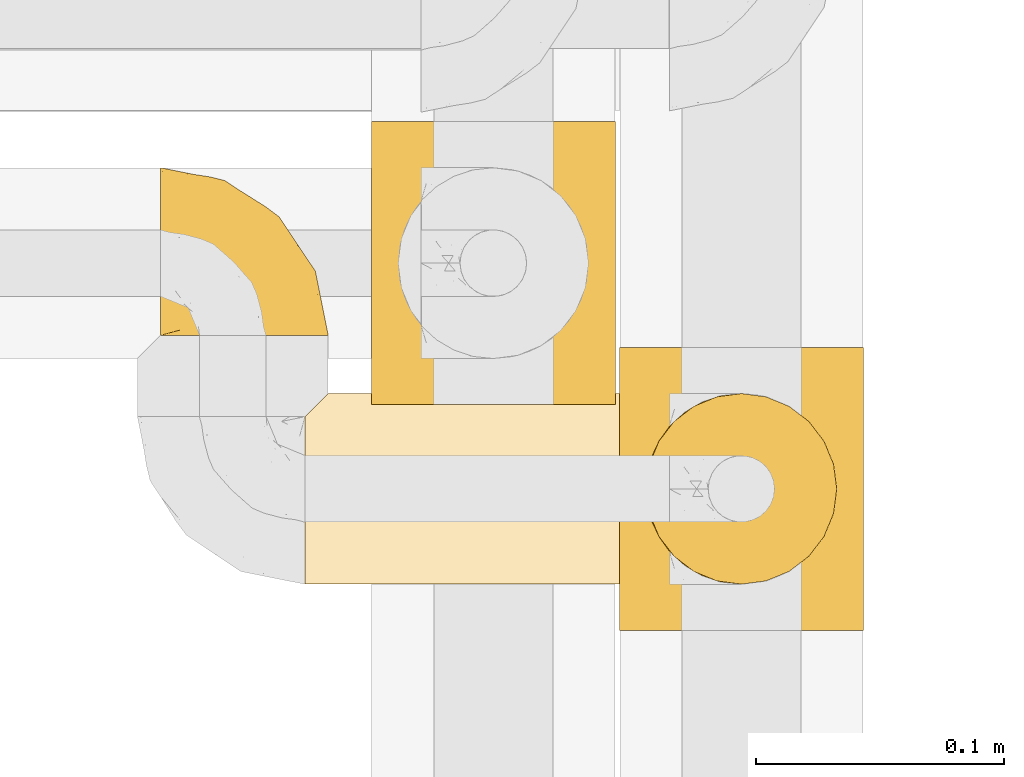
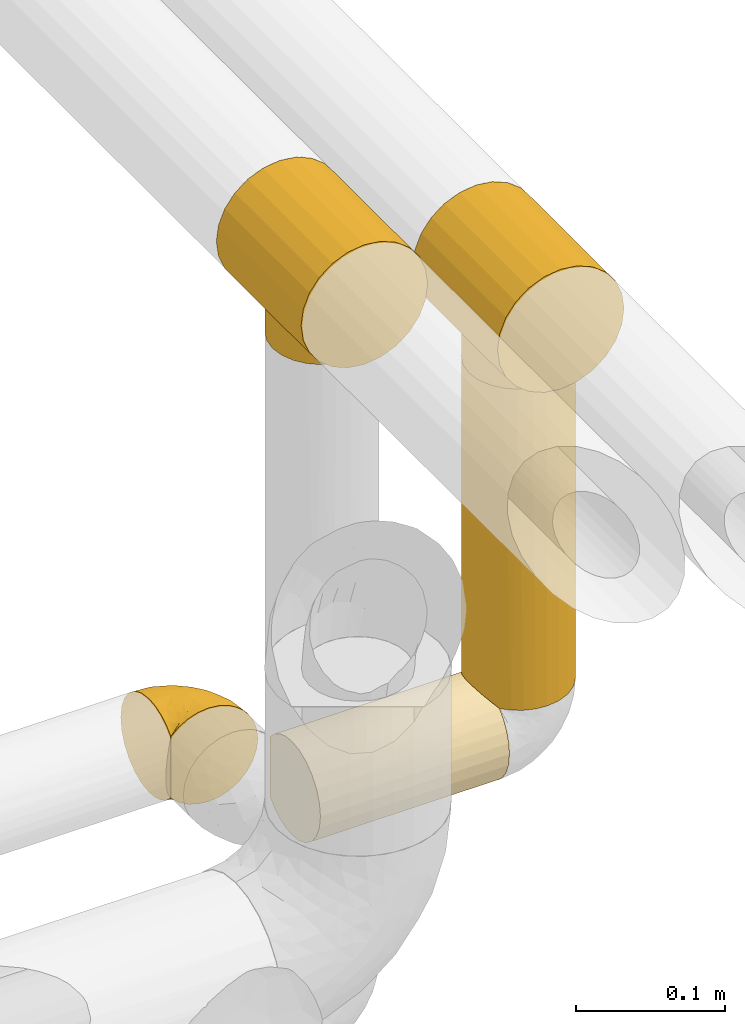
# One storey, part 496 of 827: 5 coverings.
"""IFC2X3 building model written with IfcOpenShell, lengths in millimetres."""

from ifc_helpers import new_model, entity, si_unit, converted_unit, derived_unit, direction, frame, origin, place, context, subcontext, project, spatial, faceted_brep, element, save


model = new_model("IFC2X3")

# Units and contexts
model_context = context("Model", 3, precision=0.01, world=origin(), true_north=direction((6.12303176911189e-17, 1.0)))
body_context = subcontext(model_context, "Body", "Model", "MODEL_VIEW")
ifc_project = project(units=[si_unit("LENGTHUNIT", "METRE", prefix="MILLI"), si_unit("AREAUNIT", "SQUARE_METRE"), si_unit("VOLUMEUNIT", "CUBIC_METRE"), converted_unit("PLANEANGLEUNIT", "DEGREE", entity("IfcRatioMeasure", 0.0174532925199433), si_unit("PLANEANGLEUNIT", "RADIAN"), dimensions=[0, 0, 0, 0, 0, 0, 0]), si_unit("MASSUNIT", "GRAM", prefix="KILO"), derived_unit("MASSDENSITYUNIT", [(si_unit("MASSUNIT", "GRAM", prefix="KILO"), 1), (si_unit("LENGTHUNIT", "METRE"), -3)]), derived_unit("MOMENTOFINERTIAUNIT", [(si_unit("LENGTHUNIT", "METRE"), 4)]), si_unit("TIMEUNIT", "SECOND"), si_unit("FREQUENCYUNIT", "HERTZ"), si_unit("THERMODYNAMICTEMPERATUREUNIT", "DEGREE_CELSIUS"), derived_unit("THERMALTRANSMITTANCEUNIT", [(si_unit("MASSUNIT", "GRAM", prefix="KILO"), 1), (si_unit("THERMODYNAMICTEMPERATUREUNIT", "KELVIN"), -1), (si_unit("TIMEUNIT", "SECOND"), -3)]), derived_unit("VOLUMETRICFLOWRATEUNIT", [(si_unit("LENGTHUNIT", "METRE"), 3), (si_unit("TIMEUNIT", "SECOND"), -1)]), derived_unit("MASSFLOWRATEUNIT", [(si_unit("MASSUNIT", "GRAM", prefix="KILO"), 1), (si_unit("TIMEUNIT", "SECOND"), -1)]), derived_unit("ROTATIONALFREQUENCYUNIT", [(si_unit("TIMEUNIT", "SECOND"), -1)]), si_unit("ELECTRICCURRENTUNIT", "AMPERE"), si_unit("ELECTRICVOLTAGEUNIT", "VOLT"), si_unit("POWERUNIT", "WATT"), si_unit("FORCEUNIT", "NEWTON", prefix="KILO"), si_unit("ILLUMINANCEUNIT", "LUX"), si_unit("LUMINOUSFLUXUNIT", "LUMEN"), si_unit("LUMINOUSINTENSITYUNIT", "CANDELA"), derived_unit("USERDEFINED", [(si_unit("MASSUNIT", "GRAM", prefix="KILO"), -1), (si_unit("LENGTHUNIT", "METRE"), -2), (si_unit("TIMEUNIT", "SECOND"), 3), (si_unit("LUMINOUSFLUXUNIT", "LUMEN"), 1)]), derived_unit("LINEARVELOCITYUNIT", [(si_unit("LENGTHUNIT", "METRE"), 1), (si_unit("TIMEUNIT", "SECOND"), -1)]), si_unit("PRESSUREUNIT", "PASCAL"), derived_unit("USERDEFINED", [(si_unit("LENGTHUNIT", "METRE"), -2), (si_unit("MASSUNIT", "GRAM", prefix="KILO"), 1), (si_unit("TIMEUNIT", "SECOND"), -2)]), derived_unit("LINEARFORCEUNIT", [(si_unit("MASSUNIT", "GRAM", prefix="KILO"), 1), (si_unit("LENGTHUNIT", "METRE"), 1), (si_unit("TIMEUNIT", "SECOND"), -2), (si_unit("LENGTHUNIT", "METRE"), -1)]), derived_unit("PLANARFORCEUNIT", [(si_unit("MASSUNIT", "GRAM", prefix="KILO"), 1), (si_unit("LENGTHUNIT", "METRE"), 1), (si_unit("TIMEUNIT", "SECOND"), -2), (si_unit("LENGTHUNIT", "METRE"), -2)])], contexts=[model_context])

# Site, building, storey
site_placement = place(None, origin())
site = spatial("IfcSite", under=ifc_project, at=site_placement, CompositionType="ELEMENT")
building_placement = place(site_placement, origin())
building = spatial("IfcBuilding", under=site, at=building_placement, CompositionType="ELEMENT")
storey_placement = place(building_placement, frame((0.0, 0.0, 28200.0)))
storey = spatial("IfcBuildingStorey", under=building, at=storey_placement, Name="08", CompositionType="ELEMENT", Elevation=28200.0)

# Coverings
covering_1_placement = place(storey_placement, frame((61001.89, 16322.84, 2942.74)))
element("IfcCovering", 1, at=covering_1_placement, inside=storey, Name=":ADSK_", ObjectType=":ADSK_", PredefinedType="INSULATION", context=body_context, shape_type="Brep", body=[
    faceted_brep([(26.17, 114.0, 99.57), (38.02, 114.0, 104.48), (50.75, 114.0, 106.15), (63.47, 114.0, 104.48), (75.32, 114.0, 99.57), (85.5, 114.0, 91.75), (93.31, 114.0, 81.58), (98.22, 114.0, 69.72), (99.9, 114.0, 57.0), (98.22, 114.0, 44.28), (93.31, 114.0, 32.43), (85.5, 114.0, 22.25), (80.41, 114.0, 18.34), (75.32, 114.0, 14.43), (69.39, 114.0, 11.98), (63.47, 114.0, 9.52), (60.29, 114.0, 9.11), (57.11, 114.0, 8.69), (53.93, 114.0, 8.27), (50.75, 114.0, 7.85), (47.57, 114.0, 8.27), (44.38, 114.0, 8.69), (41.2, 114.0, 9.11), (38.02, 114.0, 9.52), (32.1, 114.0, 11.98), (26.17, 114.0, 14.43), (21.08, 114.0, 18.34), (15.99, 114.0, 22.25), (8.18, 114.0, 32.43), (3.27, 114.0, 44.28), (1.6, 114.0, 57.0), (3.27, 114.0, 69.72), (8.18, 114.0, 81.58), (15.99, 114.0, 91.75), (98.22, 0.0, 69.72), (93.31, 0.0, 81.58), (85.5, 0.0, 91.75), (75.32, 0.0, 99.57), (63.47, 0.0, 104.48), (50.75, 0.0, 106.15), (38.02, 0.0, 104.48), (26.17, 0.0, 99.57), (15.99, 0.0, 91.75), (8.18, 0.0, 81.58), (3.27, 0.0, 69.72), (1.6, 0.0, 57.0), (3.27, 0.0, 44.28), (8.18, 0.0, 32.43), (15.99, 0.0, 22.25), (21.08, 0.0, 18.34), (26.17, 0.0, 14.43), (32.1, 0.0, 11.98), (38.02, 0.0, 9.52), (41.2, 0.0, 9.11), (44.38, 0.0, 8.69), (47.57, 0.0, 8.27), (50.75, 0.0, 7.85), (53.93, 0.0, 8.27), (57.11, 0.0, 8.69), (60.29, 0.0, 9.11), (63.47, 0.0, 9.52), (69.39, 0.0, 11.98), (75.32, 0.0, 14.43), (80.41, 0.0, 18.34), (85.5, 0.0, 22.25), (93.31, 0.0, 32.43), (98.22, 0.0, 44.28), (99.9, 0.0, 57.0), (80.86, 33.09, 18.16), (85.26, 40.05, 22.01), (75.08, 27.23, 14.3), (67.99, 91.37, 10.97), (88.15, 48.08, 25.11), (89.2, 57.0, 26.38), (88.15, 65.92, 25.11), (50.75, 95.45, 7.85), (50.75, 18.55, 7.85), (80.86, 80.91, 18.16), (85.26, 73.95, 22.01), (75.08, 86.77, 14.3), (67.99, 22.63, 10.97), (63.86, 92.88, 9.83), (59.73, 19.61, 8.68), (55.24, 19.08, 8.26), (63.86, 21.12, 9.83), (59.73, 94.39, 8.68), (55.24, 94.92, 8.26), (46.25, 19.08, 8.26), (37.63, 21.12, 9.83), (26.41, 27.23, 14.3), (41.76, 19.61, 8.68), (33.5, 22.63, 10.97), (37.63, 92.88, 9.83), (41.76, 94.39, 8.68), (46.25, 94.92, 8.26), (26.41, 86.77, 14.3), (33.5, 91.37, 10.97), (20.63, 80.91, 18.16), (20.63, 33.09, 18.16), (16.23, 40.05, 22.01), (13.34, 48.08, 25.11), (12.3, 57.0, 26.38), (16.23, 73.95, 22.01), (13.34, 65.92, 25.11), (89.2, 57.0, 0.0), (87.89, 47.05, 0.0), (84.04, 37.77, 0.0), (77.93, 29.81, 0.0), (69.97, 23.7, 0.0), (60.7, 19.86, 0.0), (50.75, 18.55, 0.0), (40.79, 19.86, 0.0), (31.52, 23.7, 0.0), (23.56, 29.81, 0.0), (17.45, 37.77, 0.0), (13.61, 47.05, 0.0), (12.3, 57.0, 0.0), (13.61, 66.95, 0.0), (17.45, 76.22, 0.0), (23.56, 84.19, 0.0), (31.52, 90.3, 0.0), (40.79, 94.14, 0.0), (50.75, 95.45, 0.0), (60.7, 94.14, 0.0), (69.97, 90.3, 0.0), (77.93, 84.19, 0.0), (84.04, 76.22, 0.0), (87.89, 66.95, 0.0)], [[[0, 1, 2, 3, 4, 5, 6, 7, 8, 9, 10, 11, 12, 13, 14, 15, 16, 17, 18, 19, 20, 21, 22, 23, 24, 25, 26, 27, 28, 29, 30, 31, 32, 33]], [[34, 35, 36, 37, 38, 39, 40, 41, 42, 43, 44, 45, 46, 47, 48, 49, 50, 51, 52, 53, 54, 55, 56, 57, 58, 59, 60, 61, 62, 63, 64, 65, 66, 67]], [[37, 36, 5, 4]], [[2, 39, 38, 3]], [[38, 37, 4, 3]], [[6, 35, 34, 7]], [[7, 34, 67, 8]], [[5, 36, 35, 6]], [[66, 9, 8, 67]], [[65, 10, 9, 66]], [[64, 68, 69]], [[63, 62, 70]], [[71, 15, 14]], [[69, 72, 64]], [[68, 64, 63]], [[64, 72, 65]], [[72, 73, 65]], [[74, 11, 10]], [[18, 75, 19]], [[76, 57, 56]], [[77, 11, 78]], [[78, 11, 74]], [[79, 12, 77]], [[74, 10, 73]], [[73, 10, 65]], [[70, 61, 80]], [[61, 70, 62]], [[80, 61, 60]], [[15, 71, 81]], [[82, 59, 58]], [[83, 57, 76]], [[84, 59, 82]], [[82, 58, 83]], [[83, 58, 57]], [[60, 84, 80]], [[17, 85, 86]], [[79, 13, 12]], [[59, 84, 60]], [[79, 14, 13]], [[14, 79, 71]], [[85, 17, 16]], [[77, 12, 11]], [[18, 17, 86]], [[15, 81, 16]], [[16, 81, 85]], [[75, 18, 86]], [[68, 63, 70]], [[54, 87, 55]], [[53, 52, 88]], [[76, 55, 87]], [[50, 89, 51]], [[54, 90, 87]], [[91, 51, 89]], [[91, 52, 51]], [[88, 90, 53]], [[92, 22, 93]], [[93, 21, 94]], [[75, 20, 19]], [[55, 76, 56]], [[20, 75, 94]], [[95, 25, 24]], [[90, 54, 53]], [[24, 23, 96]], [[95, 97, 26]], [[96, 23, 92]], [[89, 49, 98]], [[89, 50, 49]], [[94, 21, 20]], [[98, 48, 99]], [[48, 98, 49]], [[99, 48, 100]], [[52, 91, 88]], [[28, 47, 46, 29]], [[101, 100, 47]], [[47, 100, 48]], [[46, 45, 30, 29]], [[93, 22, 21]], [[102, 103, 27]], [[95, 24, 96]], [[26, 25, 95]], [[27, 97, 102]], [[103, 28, 27]], [[22, 92, 23]], [[101, 28, 103]], [[101, 47, 28]], [[97, 27, 26]], [[31, 44, 43, 32]], [[32, 43, 42, 33]], [[45, 44, 31, 30]], [[0, 41, 40, 1]], [[1, 40, 39, 2]], [[33, 42, 41, 0]], [[104, 105, 106, 107, 108, 109, 110, 111, 112, 113, 114, 115, 116, 117, 118, 119, 120, 121, 122, 123, 124, 125, 126, 127]], [[82, 110, 109]], [[80, 109, 108]], [[110, 82, 83, 76]], [[70, 80, 108]], [[109, 80, 84, 82]], [[108, 107, 70]], [[107, 106, 68]], [[106, 105, 69]], [[72, 105, 104]], [[68, 106, 69]], [[72, 69, 105]], [[73, 72, 104]], [[107, 68, 70]], [[74, 104, 127]], [[78, 127, 126]], [[73, 104, 74]], [[74, 127, 78]], [[126, 77, 78]], [[126, 125, 77]], [[79, 125, 124]], [[124, 123, 71]], [[122, 85, 123]], [[71, 79, 124]], [[122, 75, 86, 85]], [[123, 85, 81, 71]], [[125, 79, 77]], [[93, 122, 121]], [[96, 121, 120]], [[122, 93, 94, 75]], [[95, 96, 120]], [[121, 96, 92, 93]], [[120, 119, 95]], [[97, 119, 118]], [[118, 117, 102]], [[116, 103, 117]], [[97, 118, 102]], [[103, 102, 117]], [[101, 103, 116]], [[119, 97, 95]], [[100, 116, 115]], [[99, 115, 114]], [[101, 116, 100]], [[100, 115, 99]], [[114, 98, 99]], [[114, 113, 98]], [[89, 113, 112]], [[112, 111, 91]], [[110, 90, 111]], [[91, 89, 112]], [[110, 76, 87, 90]], [[111, 90, 88, 91]], [[113, 89, 98]]]),
])
covering_2_placement = place(storey_placement, frame((61101.89, 16231.88, 2942.74)))
element("IfcCovering", 2, at=covering_2_placement, inside=storey, Name=":ADSK_", ObjectType=":ADSK_", PredefinedType="INSULATION", context=body_context, shape_type="Brep", body=[
    faceted_brep([(26.17, 114.0, 99.57), (38.02, 114.0, 104.48), (50.75, 114.0, 106.15), (63.47, 114.0, 104.48), (75.32, 114.0, 99.57), (85.5, 114.0, 91.75), (93.31, 114.0, 81.58), (98.22, 114.0, 69.72), (99.9, 114.0, 57.0), (98.22, 114.0, 44.28), (93.31, 114.0, 32.43), (85.5, 114.0, 22.25), (80.41, 114.0, 18.34), (75.32, 114.0, 14.43), (69.39, 114.0, 11.98), (63.47, 114.0, 9.52), (60.29, 114.0, 9.11), (57.11, 114.0, 8.69), (53.93, 114.0, 8.27), (50.75, 114.0, 7.85), (47.57, 114.0, 8.27), (44.38, 114.0, 8.69), (41.2, 114.0, 9.11), (38.02, 114.0, 9.52), (32.1, 114.0, 11.98), (26.17, 114.0, 14.43), (21.08, 114.0, 18.34), (15.99, 114.0, 22.25), (8.18, 114.0, 32.43), (3.27, 114.0, 44.28), (1.6, 114.0, 57.0), (3.27, 114.0, 69.72), (8.18, 114.0, 81.58), (15.99, 114.0, 91.75), (98.22, 0.0, 69.72), (93.31, 0.0, 81.58), (85.5, 0.0, 91.75), (75.32, 0.0, 99.57), (63.47, 0.0, 104.48), (50.75, 0.0, 106.15), (38.02, 0.0, 104.48), (26.17, 0.0, 99.57), (15.99, 0.0, 91.75), (8.18, 0.0, 81.58), (3.27, 0.0, 69.72), (1.6, 0.0, 57.0), (3.27, 0.0, 44.28), (8.18, 0.0, 32.43), (15.99, 0.0, 22.25), (21.08, 0.0, 18.34), (26.17, 0.0, 14.43), (32.1, 0.0, 11.98), (38.02, 0.0, 9.52), (41.2, 0.0, 9.11), (44.38, 0.0, 8.69), (47.57, 0.0, 8.27), (50.75, 0.0, 7.85), (53.93, 0.0, 8.27), (57.11, 0.0, 8.69), (60.29, 0.0, 9.11), (63.47, 0.0, 9.52), (69.39, 0.0, 11.98), (75.32, 0.0, 14.43), (80.41, 0.0, 18.34), (85.5, 0.0, 22.25), (93.31, 0.0, 32.43), (98.22, 0.0, 44.28), (99.9, 0.0, 57.0), (80.86, 33.09, 18.16), (85.26, 40.05, 22.01), (75.08, 27.23, 14.3), (67.99, 91.37, 10.97), (88.15, 48.08, 25.11), (89.2, 57.0, 26.38), (88.15, 65.92, 25.11), (50.75, 95.45, 7.85), (50.75, 18.55, 7.85), (80.86, 80.91, 18.16), (85.26, 73.95, 22.01), (75.08, 86.77, 14.3), (67.99, 22.63, 10.97), (63.86, 92.88, 9.83), (59.73, 19.61, 8.68), (55.24, 19.08, 8.26), (63.86, 21.12, 9.83), (59.73, 94.39, 8.68), (55.24, 94.92, 8.26), (46.25, 19.08, 8.26), (37.63, 21.12, 9.83), (26.41, 27.23, 14.3), (41.76, 19.61, 8.68), (33.5, 22.63, 10.97), (37.63, 92.88, 9.83), (41.76, 94.39, 8.68), (46.25, 94.92, 8.26), (26.41, 86.77, 14.3), (33.5, 91.37, 10.97), (20.63, 80.91, 18.16), (20.63, 33.09, 18.16), (16.23, 40.05, 22.01), (13.34, 48.08, 25.11), (12.3, 57.0, 26.38), (16.23, 73.95, 22.01), (13.34, 65.92, 25.11), (89.2, 57.0, 0.0), (87.89, 47.05, 0.0), (84.04, 37.77, 0.0), (77.93, 29.81, 0.0), (69.97, 23.7, 0.0), (60.7, 19.86, 0.0), (50.75, 18.55, 0.0), (40.79, 19.86, 0.0), (31.52, 23.7, 0.0), (23.56, 29.81, 0.0), (17.45, 37.77, 0.0), (13.61, 47.05, 0.0), (12.3, 57.0, 0.0), (13.61, 66.95, 0.0), (17.45, 76.22, 0.0), (23.56, 84.19, 0.0), (31.52, 90.3, 0.0), (40.79, 94.14, 0.0), (50.75, 95.45, 0.0), (60.7, 94.14, 0.0), (69.97, 90.3, 0.0), (77.93, 84.19, 0.0), (84.04, 76.22, 0.0), (87.89, 66.95, 0.0)], [[[0, 1, 2, 3, 4, 5, 6, 7, 8, 9, 10, 11, 12, 13, 14, 15, 16, 17, 18, 19, 20, 21, 22, 23, 24, 25, 26, 27, 28, 29, 30, 31, 32, 33]], [[34, 35, 36, 37, 38, 39, 40, 41, 42, 43, 44, 45, 46, 47, 48, 49, 50, 51, 52, 53, 54, 55, 56, 57, 58, 59, 60, 61, 62, 63, 64, 65, 66, 67]], [[37, 36, 5, 4]], [[2, 39, 38, 3]], [[38, 37, 4, 3]], [[6, 35, 34, 7]], [[7, 34, 67, 8]], [[5, 36, 35, 6]], [[66, 9, 8, 67]], [[65, 10, 9, 66]], [[64, 68, 69]], [[63, 62, 70]], [[71, 15, 14]], [[69, 72, 64]], [[68, 64, 63]], [[64, 72, 65]], [[72, 73, 65]], [[74, 11, 10]], [[18, 75, 19]], [[76, 57, 56]], [[77, 11, 78]], [[78, 11, 74]], [[79, 12, 77]], [[74, 10, 73]], [[73, 10, 65]], [[70, 61, 80]], [[61, 70, 62]], [[80, 61, 60]], [[15, 71, 81]], [[82, 59, 58]], [[83, 57, 76]], [[84, 59, 82]], [[82, 58, 83]], [[83, 58, 57]], [[60, 84, 80]], [[17, 85, 86]], [[79, 13, 12]], [[59, 84, 60]], [[79, 14, 13]], [[14, 79, 71]], [[85, 17, 16]], [[77, 12, 11]], [[18, 17, 86]], [[15, 81, 16]], [[16, 81, 85]], [[75, 18, 86]], [[68, 63, 70]], [[54, 87, 55]], [[53, 52, 88]], [[76, 55, 87]], [[50, 89, 51]], [[54, 90, 87]], [[91, 51, 89]], [[91, 52, 51]], [[88, 90, 53]], [[92, 22, 93]], [[93, 21, 94]], [[75, 20, 19]], [[55, 76, 56]], [[20, 75, 94]], [[95, 25, 24]], [[90, 54, 53]], [[24, 23, 96]], [[95, 97, 26]], [[96, 23, 92]], [[89, 49, 98]], [[89, 50, 49]], [[94, 21, 20]], [[98, 48, 99]], [[48, 98, 49]], [[99, 48, 100]], [[52, 91, 88]], [[28, 47, 46, 29]], [[101, 100, 47]], [[47, 100, 48]], [[46, 45, 30, 29]], [[93, 22, 21]], [[102, 103, 27]], [[95, 24, 96]], [[26, 25, 95]], [[27, 97, 102]], [[103, 28, 27]], [[22, 92, 23]], [[101, 28, 103]], [[101, 47, 28]], [[97, 27, 26]], [[31, 44, 43, 32]], [[32, 43, 42, 33]], [[45, 44, 31, 30]], [[0, 41, 40, 1]], [[1, 40, 39, 2]], [[33, 42, 41, 0]], [[104, 105, 106, 107, 108, 109, 110, 111, 112, 113, 114, 115, 116, 117, 118, 119, 120, 121, 122, 123, 124, 125, 126, 127]], [[82, 110, 109]], [[80, 109, 108]], [[110, 82, 83, 76]], [[70, 80, 108]], [[109, 80, 84, 82]], [[108, 107, 70]], [[107, 106, 68]], [[106, 105, 69]], [[72, 105, 104]], [[68, 106, 69]], [[72, 69, 105]], [[73, 72, 104]], [[107, 68, 70]], [[74, 104, 127]], [[78, 127, 126]], [[73, 104, 74]], [[74, 127, 78]], [[126, 77, 78]], [[126, 125, 77]], [[79, 125, 124]], [[124, 123, 71]], [[122, 85, 123]], [[71, 79, 124]], [[122, 75, 86, 85]], [[123, 85, 81, 71]], [[125, 79, 77]], [[93, 122, 121]], [[96, 121, 120]], [[122, 93, 94, 75]], [[95, 96, 120]], [[121, 96, 92, 93]], [[120, 119, 95]], [[97, 119, 118]], [[118, 117, 102]], [[116, 103, 117]], [[97, 118, 102]], [[103, 102, 117]], [[101, 103, 116]], [[119, 97, 95]], [[100, 116, 115]], [[99, 115, 114]], [[101, 116, 100]], [[100, 115, 99]], [[114, 98, 99]], [[114, 113, 98]], [[89, 113, 112]], [[112, 111, 91]], [[110, 90, 111]], [[91, 89, 112]], [[110, 76, 87, 90]], [[111, 90, 88, 91]], [[113, 89, 98]]]),
])
covering_3_placement = place(storey_placement, frame((61112.64, 16248.88, 2677.5)))
element("IfcCovering", 3, at=covering_3_placement, inside=storey, Name=":ADSK_", ObjectType=":ADSK_", PredefinedType="INSULATION", context=body_context, shape_type="Brep", body=[
    faceted_brep([(77.09, 30.06, 265.24), (78.4, 40.0, 265.24), (77.09, 49.93, 265.24), (73.25, 59.2, 265.24), (67.15, 67.15, 265.24), (59.2, 73.25, 265.24), (49.93, 77.09, 265.24), (40.0, 78.4, 265.24), (30.06, 77.09, 265.24), (20.8, 73.25, 265.24), (12.84, 67.15, 265.24), (6.74, 59.2, 265.24), (2.9, 49.93, 265.24), (1.6, 40.0, 265.24), (2.9, 30.06, 265.24), (6.74, 20.8, 265.24), (12.84, 12.84, 265.24), (20.8, 6.74, 265.24), (30.06, 2.9, 265.24), (40.0, 1.6, 265.24), (49.93, 2.9, 265.24), (59.2, 6.74, 265.24), (67.15, 12.84, 265.24), (73.25, 20.8, 265.24), (77.09, 49.93, 1.6), (78.4, 40.0, 1.6), (77.09, 30.06, 1.6), (73.25, 20.8, 1.6), (67.15, 12.84, 1.6), (59.2, 6.74, 1.6), (49.93, 2.9, 1.6), (40.0, 1.6, 1.6), (31.79, 2.48, 1.6), (23.98, 5.09, 1.6), (16.91, 9.31, 1.6), (10.9, 14.94, 1.6), (10.9, 65.05, 1.6), (16.91, 70.68, 1.6), (23.98, 74.9, 1.6), (31.79, 77.51, 1.6), (40.0, 78.4, 1.6), (49.93, 77.09, 1.6), (59.2, 73.25, 1.6), (67.15, 67.15, 1.6), (73.25, 59.2, 1.6), (2.2, 33.21, 10.29), (4.0, 26.63, 8.5), (6.92, 20.48, 5.57), (1.6, 40.0, 10.9), (6.92, 59.51, 5.57), (4.0, 53.36, 8.5), (2.2, 46.78, 10.29)], [[[0, 1, 2, 3, 4, 5, 6, 7, 8, 9, 10, 11, 12, 13, 14, 15, 16, 17, 18, 19, 20, 21, 22, 23]], [[24, 25, 26, 27, 28, 29, 30, 31, 32, 33, 34, 35, 36, 37, 38, 39, 40, 41, 42, 43, 44]], [[45, 46, 14]], [[47, 35, 15]], [[46, 47, 15]], [[48, 45, 13]], [[13, 45, 14]], [[46, 15, 14]], [[35, 16, 15]], [[17, 34, 33]], [[18, 33, 32]], [[19, 32, 31]], [[16, 34, 17]], [[17, 33, 18]], [[32, 19, 18]], [[34, 16, 35]], [[20, 19, 31, 30]], [[21, 20, 30, 29]], [[29, 28, 22, 21]], [[0, 23, 27, 26]], [[1, 0, 26, 25]], [[28, 27, 23, 22]], [[2, 1, 25, 24]], [[3, 2, 24, 44]], [[44, 43, 4, 3]], [[6, 5, 42, 41]], [[7, 6, 41, 40]], [[43, 42, 5, 4]], [[7, 40, 39]], [[8, 39, 38]], [[9, 38, 37]], [[7, 39, 8]], [[8, 38, 9]], [[37, 10, 9]], [[37, 36, 10]], [[36, 49, 11]], [[50, 51, 12]], [[49, 50, 11]], [[11, 50, 12]], [[13, 12, 51]], [[48, 13, 51]], [[36, 11, 10]], [[45, 48, 51, 50, 49, 36, 35, 47, 46]]]),
])
covering_4_placement = place(storey_placement, frame((60916.94, 16349.14, 2609.95)))
element("IfcCovering", 4, at=covering_4_placement, inside=storey, Name=":ADSK_", ObjectType=":ADSK_", PredefinedType="INSULATION", context=body_context, shape_type="Brep", body=[
    faceted_brep([(30.7, 1.6, 1.6), (39.26, 1.6, 2.56), (47.38, 1.6, 5.41), (54.67, 1.6, 9.99), (60.76, 1.6, 16.08), (65.34, 1.6, 23.37), (68.18, 1.6, 31.49), (69.15, 1.6, 40.05), (68.18, 1.6, 48.61), (65.33, 1.6, 56.73), (60.75, 1.6, 64.02), (54.66, 1.6, 70.11), (47.37, 1.6, 74.69), (39.25, 1.6, 77.53), (30.7, 1.6, 78.5), (22.59, 1.6, 77.63), (14.86, 1.6, 75.08), (7.84, 1.6, 70.97), (1.85, 1.6, 65.47), (1.85, 1.6, 63.27), (1.85, 1.6, 61.53), (1.85, 1.6, 59.57), (1.85, 1.6, 57.6), (1.85, 1.6, 55.63), (1.85, 1.6, 53.67), (1.85, 1.6, 51.7), (1.85, 1.6, 49.73), (1.85, 1.6, 47.54), (1.85, 1.6, 45.34), (1.85, 1.6, 43.15), (1.85, 1.6, 40.96), (1.85, 1.6, 38.76), (1.85, 1.6, 36.57), (1.85, 1.6, 34.37), (1.85, 1.6, 32.18), (1.85, 1.6, 29.98), (1.85, 1.6, 27.79), (1.85, 1.6, 25.6), (1.85, 1.6, 23.4), (1.85, 1.6, 21.21), (1.85, 1.6, 19.01), (1.85, 1.6, 16.82), (1.85, 1.6, 14.62), (7.85, 1.6, 9.12), (14.88, 1.6, 5.0), (22.61, 1.6, 2.46), (1.6, 7.85, 70.97), (1.6, 14.87, 75.09), (1.6, 22.6, 77.63), (1.6, 30.7, 78.5), (1.6, 40.65, 77.19), (1.6, 49.92, 73.34), (1.6, 57.88, 67.23), (1.6, 63.99, 59.27), (1.6, 67.84, 50.0), (1.6, 69.15, 40.05), (1.6, 67.84, 30.09), (1.6, 63.99, 20.82), (1.6, 57.88, 12.86), (1.6, 49.92, 6.75), (1.6, 40.65, 2.91), (1.6, 30.7, 1.6), (1.6, 22.6, 2.46), (1.6, 14.87, 5.0), (1.6, 7.85, 9.12), (1.6, 1.85, 14.62), (1.6, 1.85, 16.82), (1.6, 1.85, 17.8), (1.6, 1.85, 19.39), (1.6, 1.85, 20.98), (1.6, 1.85, 22.57), (1.6, 1.85, 24.16), (1.6, 1.85, 25.75), (1.6, 1.85, 27.33), (1.6, 1.85, 28.92), (1.6, 1.85, 30.51), (1.6, 1.85, 32.1), (1.6, 1.85, 33.69), (1.6, 1.85, 35.28), (1.6, 1.85, 36.87), (1.6, 1.85, 38.46), (1.6, 1.85, 40.05), (1.6, 1.85, 41.63), (1.6, 1.85, 43.22), (1.6, 1.85, 44.81), (1.6, 1.85, 46.4), (1.6, 1.85, 47.99), (1.6, 1.85, 49.58), (1.6, 1.85, 51.17), (1.6, 1.85, 52.76), (1.6, 1.85, 54.72), (1.6, 1.85, 56.69), (1.6, 1.85, 58.88), (1.6, 1.85, 61.08), (1.6, 1.85, 63.27), (1.6, 1.85, 65.47), (1.78, 1.77, 37.77), (1.77, 1.78, 36.07), (1.78, 1.77, 32.96), (1.77, 1.77, 31.36), (1.79, 1.76, 56.52), (1.78, 1.77, 54.96), (1.76, 1.79, 18.75), (1.77, 1.78, 58.07), (1.77, 1.78, 50.37), (1.76, 1.78, 23.36), (1.77, 1.78, 24.95), (1.77, 1.78, 42.43), (1.8, 1.74, 15.97), (1.76, 1.78, 51.96), (1.77, 1.78, 53.47), (1.78, 1.77, 48.63), (1.77, 1.78, 63.93), (1.77, 1.78, 40.93), (1.76, 1.78, 29.72), (1.77, 1.77, 62.4), (1.78, 1.77, 60.92), (1.77, 1.77, 17.31), (1.77, 1.78, 21.74), (1.77, 1.78, 34.56), (1.78, 1.77, 20.18), (1.77, 1.77, 14.62), (1.8, 1.72, 14.62), (1.82, 1.66, 14.62), (1.77, 1.77, 65.47), (1.72, 1.8, 65.47), (1.66, 1.82, 65.47), (1.76, 1.79, 59.5), (1.77, 1.78, 47.1), (1.76, 1.79, 45.61), (1.77, 1.78, 28.18), (1.66, 1.82, 14.62), (1.72, 1.8, 14.62), (1.78, 1.76, 26.61), (1.82, 1.66, 65.47), (1.8, 1.72, 65.47), (1.77, 1.78, 39.32), (1.78, 1.77, 44.12), (3.72, 9.41, 72.26), (7.41, 17.65, 76.57), (6.13, 7.41, 71.77), (21.47, 21.47, 78.5), (19.34, 15.21, 77.9), (26.8, 16.15, 78.5), (8.87, 28.75, 78.5), (9.2, 13.67, 75.52), (12.79, 12.79, 76.13), (14.62, 19.18, 77.81), (7.34, 29.16, 78.5), (5.33, 9.04, 72.4), (17.64, 7.41, 76.56), (7.7, 5.74, 71.77), (9.41, 3.72, 72.25), (28.75, 8.87, 78.5), (16.15, 26.8, 78.5), (14.14, 9.53, 75.75), (29.16, 7.34, 78.5), (57.02, 37.63, 50.46), (64.92, 17.92, 52.75), (64.0, 27.45, 40.05), (11.92, 37.01, 77.7), (19.16, 34.22, 77.66), (28.65, 45.87, 71.02), (24.62, 56.57, 63.45), (15.19, 52.31, 70.55), (18.36, 42.07, 75.57), (9.2, 44.74, 75.57), (46.98, 21.49, 72.61), (50.24, 11.02, 72.61), (56.1, 15.64, 67.24), (28.97, 26.02, 77.74), (54.46, 36.59, 57.43), (21.34, 65.49, 47.19), (18.4, 63.99, 54.76), (66.44, 15.2, 40.05), (12.07, 60.27, 63.45), (45.49, 45.25, 60.1), (50.57, 35.21, 63.72), (36.04, 22.52, 76.83), (42.07, 12.03, 76.34), (62.12, 13.32, 60.51), (37.37, 35.9, 72.59), (29.39, 33.87, 76.05), (53.59, 25.73, 66.15), (58.06, 26.34, 60.51), (49.27, 46.78, 51.88), (29.63, 59.54, 55.34), (33.21, 60.18, 48.67), (40.1, 53.93, 53.89), (44.08, 53.36, 46.73), (49.36, 49.36, 40.05), (56.68, 38.4, 40.05), (15.2, 66.44, 40.05), (35.57, 50.09, 63.95), (41.7, 41.08, 67.24), (46.4, 31.14, 69.62), (41.41, 28.19, 73.6), (27.45, 64.0, 40.05), (38.4, 56.68, 40.05), (12.99, 43.9, 4.52), (21.33, 65.46, 32.72), (42.89, 52.22, 27.18), (57.04, 37.61, 29.63), (56.11, 15.64, 12.86), (62.13, 13.31, 19.59), (21.89, 50.02, 9.54), (16.62, 59.28, 16.64), (32.9, 53.05, 17.48), (46.99, 21.48, 7.49), (50.25, 11.01, 7.49), (42.08, 12.03, 3.75), (49.91, 41.02, 20.75), (15.6, 35.39, 2.33), (16.15, 26.8, 1.6), (8.87, 28.75, 1.6), (29.16, 7.34, 1.6), (13.16, 65.81, 26.94), (10.83, 53.28, 9.54), (33.8, 59.8, 31.21), (25.02, 61.82, 25.33), (64.92, 17.91, 27.35), (32.83, 41.4, 8.17), (20.56, 40.48, 4.3), (58.07, 26.34, 19.59), (21.46, 31.68, 2.23), (28.1, 27.68, 2.45), (26.8, 16.15, 1.6), (21.47, 21.47, 1.6), (51.29, 28.05, 12.86), (36.04, 22.54, 3.27), (28.75, 8.87, 1.6), (8.45, 37.3, 2.29), (41.73, 41.07, 12.86), (39.27, 32.24, 6.89), (33.56, 47.4, 12.43), (27.29, 35.77, 4.1), (7.41, 17.65, 3.53), (3.51, 11.06, 6.88), (4.68, 8.55, 8.16), (5.52, 6.63, 9.02), (8.75, 12.77, 5.0), (12.79, 12.79, 3.96), (17.65, 7.41, 3.52), (13.9, 18.97, 2.4), (9.42, 3.72, 7.83), (7.68, 5.76, 8.32), (19.33, 15.21, 2.19), (14.13, 9.52, 4.34)], [[[0, 1, 2, 3, 4, 5, 6, 7, 8, 9, 10, 11, 12, 13, 14, 15, 16, 17, 18, 19, 20, 21, 22, 23, 24, 25, 26, 27, 28, 29, 30, 31, 32, 33, 34, 35, 36, 37, 38, 39, 40, 41, 42, 43, 44, 45]], [[46, 47, 48, 49, 50, 51, 52, 53, 54, 55, 56, 57, 58, 59, 60, 61, 62, 63, 64, 65, 66, 67, 68, 69, 70, 71, 72, 73, 74, 75, 76, 77, 78, 79, 80, 81, 82, 83, 84, 85, 86, 87, 88, 89, 90, 91, 92, 93, 94, 95]], [[96, 97, 32]], [[98, 76, 99]], [[100, 101, 23]], [[68, 67, 102]], [[22, 21, 103]], [[26, 25, 104]], [[22, 103, 100]], [[71, 105, 106]], [[83, 82, 107]], [[88, 87, 104]], [[108, 66, 65]], [[109, 110, 89]], [[111, 27, 26]], [[112, 19, 18]], [[81, 113, 82]], [[109, 25, 24]], [[114, 75, 74]], [[105, 38, 106]], [[104, 111, 26]], [[20, 115, 116]], [[97, 96, 79]], [[66, 108, 117]], [[105, 70, 118]], [[33, 97, 119]], [[102, 120, 68]], [[108, 121, 122, 123, 42]], [[112, 94, 115]], [[19, 115, 20]], [[93, 116, 115]], [[117, 67, 66]], [[40, 117, 41]], [[112, 124, 125, 126, 95]], [[19, 112, 115]], [[69, 120, 118]], [[41, 117, 108]], [[120, 40, 39]], [[120, 39, 118]], [[120, 69, 68]], [[116, 93, 127]], [[128, 85, 129]], [[117, 40, 102]], [[73, 130, 74]], [[99, 35, 34]], [[115, 94, 93]], [[41, 108, 42]], [[108, 65, 131, 132, 121]], [[105, 71, 70]], [[118, 39, 38]], [[70, 69, 118]], [[37, 106, 38]], [[38, 105, 118]], [[37, 133, 106]], [[73, 72, 133]], [[106, 133, 72]], [[99, 114, 35]], [[133, 37, 36]], [[72, 71, 106]], [[94, 112, 95]], [[112, 18, 134, 135, 124]], [[130, 114, 74]], [[99, 75, 114]], [[114, 130, 35]], [[36, 35, 130]], [[77, 76, 98]], [[98, 119, 77]], [[130, 133, 36]], [[133, 130, 73]], [[78, 97, 79]], [[98, 99, 34]], [[98, 34, 33]], [[76, 75, 99]], [[97, 78, 119]], [[136, 96, 31]], [[32, 97, 33]], [[136, 31, 30]], [[80, 79, 96]], [[31, 96, 32]], [[33, 119, 98]], [[119, 78, 77]], [[96, 136, 80]], [[81, 80, 136]], [[113, 107, 82]], [[83, 107, 137]], [[107, 29, 137]], [[113, 30, 107]], [[29, 107, 30]], [[84, 83, 137]], [[137, 29, 28]], [[113, 136, 30]], [[136, 113, 81]], [[109, 88, 104]], [[85, 84, 129]], [[88, 109, 89]], [[111, 86, 128]], [[28, 129, 137]], [[87, 111, 104]], [[27, 111, 128]], [[24, 110, 109]], [[25, 109, 104]], [[110, 90, 89]], [[100, 91, 101]], [[110, 24, 101]], [[90, 110, 101]], [[116, 21, 20]], [[111, 87, 86]], [[127, 103, 21]], [[27, 128, 28]], [[85, 128, 86]], [[128, 129, 28]], [[137, 129, 84]], [[120, 102, 40]], [[117, 102, 67]], [[90, 101, 91]], [[23, 101, 24]], [[92, 91, 103]], [[100, 23, 22]], [[100, 103, 91]], [[127, 92, 103]], [[92, 127, 93]], [[116, 127, 21]], [[126, 138, 46]], [[47, 138, 139]], [[140, 125, 124]], [[141, 142, 143]], [[144, 48, 139]], [[145, 140, 146]], [[47, 139, 48]], [[139, 145, 147]], [[48, 144, 148, 49]], [[126, 125, 149]], [[16, 15, 150]], [[151, 146, 140]], [[149, 140, 145]], [[152, 151, 135]], [[152, 16, 150]], [[18, 17, 134]], [[15, 153, 150]], [[124, 151, 140]], [[141, 147, 142]], [[16, 152, 17]], [[17, 152, 134]], [[46, 95, 126]], [[139, 154, 144]], [[138, 47, 46]], [[125, 140, 149]], [[135, 134, 152]], [[146, 155, 142]], [[145, 146, 147]], [[149, 139, 138]], [[147, 141, 154]], [[147, 146, 142]], [[139, 147, 154]], [[139, 149, 145]], [[149, 138, 126]], [[155, 146, 151]], [[150, 143, 142]], [[152, 155, 151]], [[150, 142, 155]], [[15, 14, 156, 153]], [[153, 143, 150]], [[152, 150, 155]], [[151, 124, 135]], [[157, 158, 159]], [[160, 154, 161]], [[162, 163, 164]], [[165, 166, 160]], [[167, 168, 169]], [[141, 170, 161]], [[156, 14, 13]], [[158, 157, 171]], [[172, 54, 173]], [[158, 8, 174]], [[175, 53, 52]], [[51, 166, 164]], [[51, 164, 52]], [[53, 175, 173]], [[166, 51, 50]], [[176, 177, 171]], [[178, 143, 179]], [[156, 13, 179]], [[10, 9, 180]], [[169, 11, 10]], [[179, 143, 153, 156]], [[179, 13, 12]], [[168, 179, 12]], [[181, 162, 182]], [[179, 167, 178]], [[183, 184, 177]], [[183, 169, 184]], [[176, 171, 185]], [[172, 186, 187]], [[158, 9, 8]], [[159, 158, 174]], [[184, 180, 158]], [[53, 173, 54]], [[180, 169, 10]], [[188, 189, 187]], [[11, 168, 12]], [[186, 188, 187]], [[190, 157, 159, 191]], [[54, 172, 192]], [[176, 193, 194]], [[161, 170, 182]], [[162, 164, 165]], [[175, 164, 163]], [[50, 49, 148]], [[167, 195, 196]], [[178, 182, 170]], [[8, 7, 174]], [[158, 180, 9]], [[169, 180, 184]], [[169, 168, 11]], [[179, 168, 167]], [[182, 162, 165]], [[162, 194, 193]], [[161, 165, 160]], [[195, 181, 196]], [[192, 172, 197]], [[192, 55, 54]], [[189, 190, 198]], [[198, 197, 187]], [[172, 187, 197]], [[185, 189, 188]], [[198, 187, 189]], [[186, 172, 173]], [[173, 163, 186]], [[193, 186, 163]], [[176, 185, 188]], [[185, 157, 190]], [[188, 186, 193]], [[177, 176, 194]], [[188, 193, 176]], [[162, 193, 163]], [[195, 177, 194]], [[171, 177, 184]], [[181, 195, 194]], [[183, 167, 169]], [[162, 181, 194]], [[196, 182, 178]], [[158, 171, 184]], [[171, 157, 185]], [[177, 195, 183]], [[167, 183, 195]], [[182, 196, 181]], [[178, 170, 143]], [[178, 167, 196]], [[164, 175, 52]], [[173, 175, 163]], [[160, 50, 148]], [[164, 166, 165]], [[50, 160, 166]], [[160, 148, 144, 154]], [[141, 161, 154]], [[182, 165, 161]], [[190, 189, 185]], [[143, 170, 141]], [[59, 199, 60]], [[197, 200, 192]], [[201, 190, 202]], [[200, 56, 192]], [[203, 204, 4]], [[205, 206, 207]], [[208, 209, 210]], [[211, 207, 201]], [[212, 213, 214]], [[1, 215, 210]], [[216, 206, 57]], [[1, 0, 215]], [[58, 217, 59]], [[59, 217, 199]], [[2, 1, 210]], [[218, 201, 219]], [[202, 159, 220]], [[205, 221, 222]], [[223, 204, 203]], [[3, 203, 4]], [[56, 200, 216]], [[220, 5, 204]], [[220, 174, 6]], [[3, 2, 209]], [[212, 224, 213]], [[225, 226, 227]], [[228, 223, 203]], [[208, 210, 229]], [[210, 226, 229]], [[5, 220, 6]], [[57, 206, 58]], [[209, 203, 3]], [[202, 220, 223]], [[228, 203, 208]], [[202, 211, 201]], [[5, 4, 204]], [[202, 190, 191, 159]], [[210, 215, 230, 226]], [[199, 212, 231]], [[232, 233, 221]], [[233, 208, 229]], [[207, 206, 219]], [[217, 206, 205]], [[227, 224, 225]], [[233, 232, 228]], [[201, 207, 219]], [[234, 232, 221]], [[218, 219, 200]], [[202, 223, 211]], [[174, 220, 159]], [[174, 7, 6]], [[60, 231, 61]], [[220, 204, 223]], [[210, 209, 2]], [[203, 209, 208]], [[225, 233, 229]], [[224, 227, 213]], [[221, 233, 235]], [[56, 55, 192]], [[198, 218, 197]], [[200, 219, 216]], [[201, 198, 190]], [[197, 218, 200]], [[198, 201, 218]], [[206, 216, 219]], [[57, 56, 216]], [[231, 212, 214]], [[222, 212, 199]], [[228, 211, 223]], [[207, 211, 232]], [[61, 231, 214]], [[199, 231, 60]], [[233, 228, 208]], [[211, 228, 232]], [[222, 221, 235]], [[234, 205, 207]], [[206, 217, 58]], [[199, 217, 205]], [[205, 222, 199]], [[224, 222, 235]], [[222, 224, 212]], [[224, 235, 225]], [[233, 225, 235]], [[226, 225, 229]], [[205, 234, 221]], [[207, 232, 234]], [[62, 214, 236]], [[214, 213, 236]], [[214, 62, 61]], [[237, 236, 238]], [[238, 132, 131]], [[236, 237, 63]], [[239, 240, 241]], [[62, 236, 63]], [[131, 65, 64]], [[237, 131, 64]], [[242, 230, 45]], [[237, 64, 63]], [[239, 121, 132]], [[44, 242, 45]], [[241, 240, 243]], [[43, 123, 244]], [[45, 230, 215, 0]], [[244, 122, 245]], [[227, 246, 243]], [[245, 241, 247]], [[121, 239, 245]], [[43, 42, 123]], [[132, 238, 239]], [[244, 44, 43]], [[131, 237, 238]], [[240, 239, 238]], [[245, 239, 241]], [[247, 241, 246]], [[247, 244, 245]], [[238, 236, 240]], [[243, 236, 213]], [[236, 243, 240]], [[246, 241, 243]], [[243, 213, 227]], [[226, 242, 246]], [[227, 226, 246]], [[246, 242, 247]], [[244, 247, 242]], [[242, 226, 230]], [[44, 244, 242]], [[122, 244, 123]], [[122, 121, 245]]]),
])
covering_5_placement = place(storey_placement, frame((60975.14, 16248.88, 2610.0)))
element("IfcCovering", 5, at=covering_5_placement, inside=storey, Name=":ADSK_", ObjectType=":ADSK_", PredefinedType="INSULATION", context=body_context, shape_type="Brep", body=[
    faceted_brep([(148.4, 59.2, 6.74), (148.4, 67.15, 12.84), (148.4, 73.25, 20.8), (148.4, 77.09, 30.06), (148.4, 78.4, 40.0), (148.4, 77.51, 48.2), (148.4, 74.9, 56.01), (148.4, 70.68, 63.08), (148.4, 65.05, 69.1), (148.4, 14.94, 69.1), (148.4, 9.31, 63.08), (148.4, 5.09, 56.01), (148.4, 2.48, 48.2), (148.4, 1.6, 40.0), (148.4, 2.9, 30.06), (148.4, 6.74, 20.8), (148.4, 12.84, 12.84), (148.4, 20.8, 6.74), (148.4, 30.06, 2.9), (148.4, 40.0, 1.6), (148.4, 49.93, 2.9), (1.6, 69.1, 14.94), (1.6, 63.08, 9.31), (1.6, 56.01, 5.09), (1.6, 48.2, 2.48), (1.6, 40.0, 1.6), (1.6, 30.06, 2.9), (1.6, 20.8, 6.74), (1.6, 12.84, 12.84), (1.6, 6.74, 20.8), (1.6, 2.9, 30.06), (1.6, 1.6, 40.0), (1.6, 2.9, 49.93), (1.6, 6.74, 59.2), (1.6, 12.84, 67.15), (1.6, 20.8, 73.25), (1.6, 30.06, 77.09), (1.6, 40.0, 78.4), (1.6, 48.2, 77.51), (1.6, 56.01, 74.9), (1.6, 63.08, 70.68), (1.6, 69.1, 65.05), (5.57, 73.07, 20.48), (8.5, 76.0, 26.63), (10.29, 77.79, 33.21), (10.9, 78.4, 40.0), (10.29, 77.79, 46.78), (8.5, 76.0, 53.36), (5.57, 73.07, 59.51), (144.42, 59.51, 73.07), (141.5, 53.36, 76.0), (139.7, 46.78, 77.79), (139.1, 40.0, 78.4), (139.7, 33.21, 77.79), (141.5, 26.63, 76.0), (144.42, 20.48, 73.07)], [[[0, 1, 2, 3, 4, 5, 6, 7, 8, 9, 10, 11, 12, 13, 14, 15, 16, 17, 18, 19, 20]], [[21, 22, 23, 24, 25, 26, 27, 28, 29, 30, 31, 32, 33, 34, 35, 36, 37, 38, 39, 40, 41]], [[30, 29, 15, 14]], [[31, 30, 14, 13]], [[29, 28, 16, 15]], [[18, 17, 27, 26]], [[19, 18, 26, 25]], [[28, 27, 17, 16]], [[19, 25, 24]], [[20, 24, 23]], [[0, 23, 22]], [[19, 24, 20]], [[20, 23, 0]], [[22, 1, 0]], [[22, 21, 1]], [[21, 42, 2]], [[43, 44, 3]], [[42, 43, 2]], [[2, 43, 3]], [[4, 3, 44]], [[45, 4, 44]], [[21, 2, 1]], [[46, 47, 5]], [[48, 41, 7]], [[47, 48, 6]], [[45, 46, 4]], [[5, 4, 46]], [[47, 6, 5]], [[48, 7, 6]], [[41, 8, 7]], [[49, 40, 39]], [[50, 39, 38]], [[51, 38, 37]], [[49, 8, 40]], [[51, 50, 38]], [[52, 51, 37]], [[49, 39, 50]], [[40, 8, 41]], [[53, 52, 37]], [[53, 37, 36]], [[54, 36, 35]], [[54, 53, 36]], [[9, 55, 35]], [[54, 35, 55]], [[35, 34, 9]], [[10, 34, 33]], [[11, 33, 32]], [[12, 32, 31]], [[10, 33, 11]], [[11, 32, 12]], [[31, 13, 12]], [[34, 10, 9]], [[51, 52, 53, 54, 55, 9, 8, 49, 50]], [[41, 48, 47, 46, 45, 44, 43, 42, 21]]]),
])

save(model, "model.ifc")
